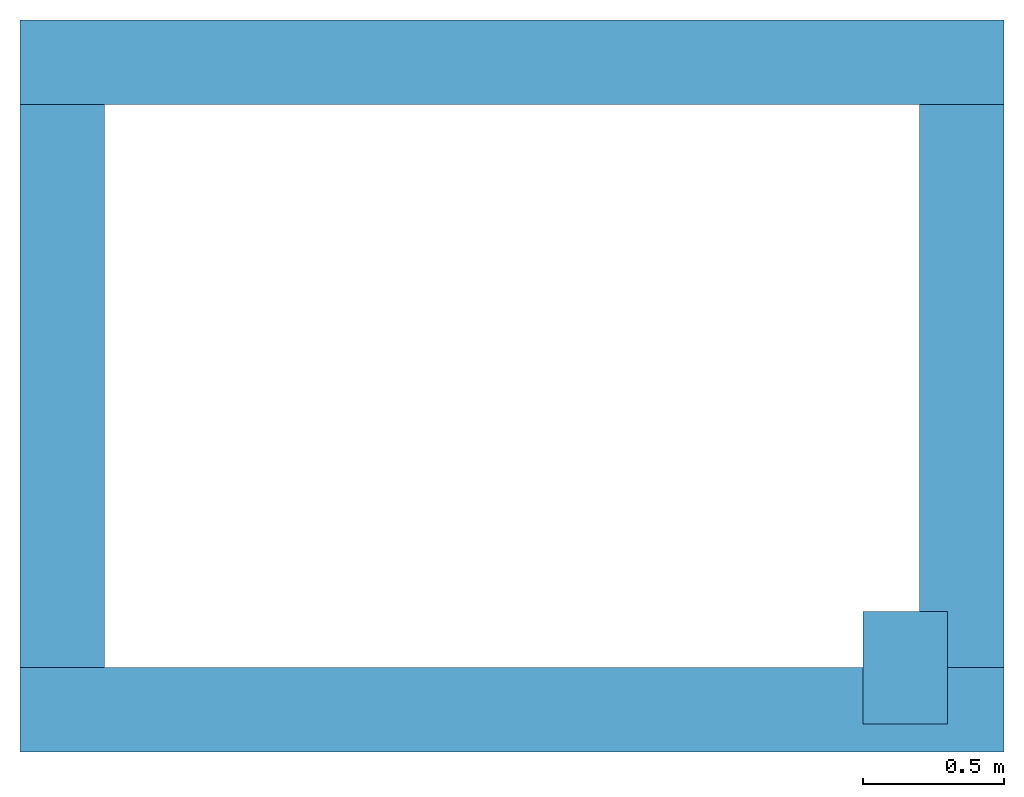
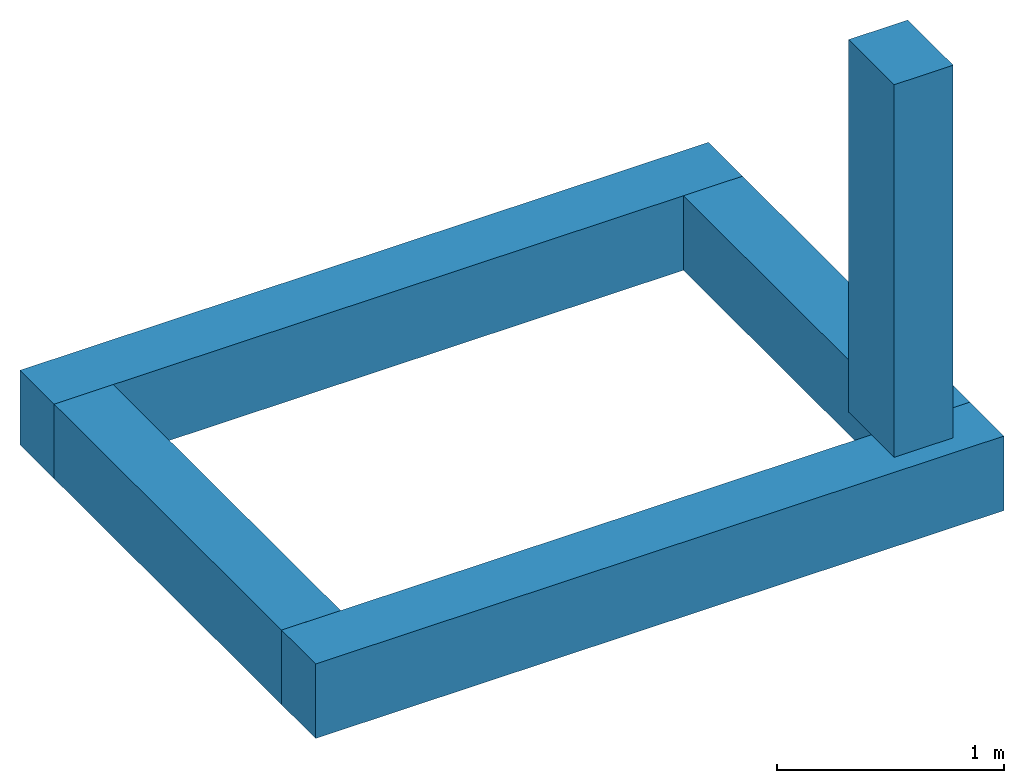
# One storey: 5 beams.
"""IFC4 building model written with IfcOpenShell, lengths in metres."""

from ifc_helpers import new_model, entity, si_unit, converted_unit, frame, frame_2d, origin_with_axes, place, context, subcontext, project, spatial, rectangle, extrude, material, material_profile, profile_set, profile_usage, type_object, element, save


model = new_model("IFC4")

# Units and contexts
model_context = context("Model", 3, precision=1e-05, world=origin_with_axes())
plan_context = context("Plan", 2, precision=1e-05, world=frame_2d((0.0, 0.0, 0.0), x_axis=(1.0, 0.0, 0.0)))
body_context = subcontext(model_context, "Body", "Model", "MODEL_VIEW")
ifc_project = project(units=[si_unit("LENGTHUNIT", "METRE"), converted_unit("PLANEANGLEUNIT", "degree", entity("IfcReal", 0.0174532925199433), si_unit("PLANEANGLEUNIT", "RADIAN"), dimensions=[0, 0, 0, 0, 0, 0, 0]), si_unit("AREAUNIT", "SQUARE_METRE"), si_unit("VOLUMEUNIT", "CUBIC_METRE")], contexts=[model_context, plan_context])

# Site, building, storey
site_placement = place(None, origin_with_axes())
site = spatial("IfcSite", under=ifc_project, at=site_placement)
building_placement = place(site_placement, origin_with_axes())
building = spatial("IfcBuilding", under=site, at=building_placement, Name="Building")
storey_placement = place(building_placement, origin_with_axes())
storey = spatial("IfcBuildingStorey", under=building, at=storey_placement, Name="Storey")

# Beams
ifc_material = material(Name="vuren")
ifc_material_profile = material_profile(ifc_material, rectangle(XDim=0.300000011920929, YDim=0.400000005960464))
ifc_profile_set = profile_set([ifc_material_profile])
ifc_profile_usage_1 = profile_usage(ifc_profile_set)
beam_type = type_object("IfcBeamType", Name="balk", PredefinedType="BEAM", material=ifc_profile_set)
beam_1_placement = place(storey_placement, frame((0.349999964237213, 0.100000113248825, -0.200000032782555), z_axis=(1.0, 4.37113882867379e-08, -4.37113882867379e-08), x_axis=(-4.37113882867379e-08, 1.0, 0.0)))
element("IfcBeam", 1, at=beam_1_placement, inside=storey, type_object=beam_type, material=ifc_profile_usage_1, Name="Beam", context=body_context, shape_type="SweptSolid", body=[
    extrude(rectangle(XDim=0.300000011920929, YDim=0.400000005960464), None, (0.0, 0.0, 1.0), 3.49483203887939),
])
ifc_profile_usage_2 = profile_usage(ifc_profile_set)
beam_2_placement = place(storey_placement, frame((0.499999970197678, 0.250000149011612, -0.200000032782555), z_axis=(-3.89414367418794e-07, 1.0, -1.62920684942947e-07), x_axis=(-1.0, -3.89414367418794e-07, -7.36919087627715e-15)))
element("IfcBeam", 2, at=beam_2_placement, inside=storey, type_object=beam_type, material=ifc_profile_usage_2, Name="Beam", context=body_context, shape_type="SweptSolid", body=[
    extrude(rectangle(XDim=0.300000011920929, YDim=0.400000005960464), None, (0.0, 0.0, 1.0), 2.0),
])
ifc_profile_usage_3 = profile_usage(ifc_profile_set)
beam_3_placement = place(storey_placement, frame((3.69483208656311, 0.250000506639481, -0.200000181794167), z_axis=(-3.89414367418794e-07, 1.0, -1.62920684942947e-07), x_axis=(-1.0, -3.89414367418794e-07, -7.36919087627715e-15)))
element("IfcBeam", 3, at=beam_3_placement, inside=storey, type_object=beam_type, material=ifc_profile_usage_3, Name="Beam", context=body_context, shape_type="SweptSolid", body=[
    extrude(rectangle(XDim=0.300000011920929, YDim=0.400000005960464), None, (0.0, 0.0, 1.0), 2.0),
])
ifc_profile_usage_4 = profile_usage(ifc_profile_set)
beam_4_placement = place(storey_placement, frame((3.49483203887939, 0.250000089406967, 0.0), z_axis=(0.0, 0.0, 1.0), x_axis=(1.0, 0.0, 0.0)))
element("IfcBeam", 4, at=beam_4_placement, inside=storey, type_object=beam_type, material=ifc_profile_usage_4, Name="Beam", context=body_context, shape_type="SweptSolid", body=[
    extrude(rectangle(XDim=0.300000011920929, YDim=0.400000005960464), None, (0.0, 0.0, 1.0), 2.0),
])
ifc_profile_usage_5 = profile_usage(ifc_profile_set)
beam_5_placement = place(storey_placement, frame((0.349999189376831, 2.40000033378601, -0.200000360608101), z_axis=(1.0, 4.37113882867379e-08, -4.37113882867379e-08), x_axis=(-4.37113882867379e-08, 1.0, 0.0)))
element("IfcBeam", 5, at=beam_5_placement, inside=storey, type_object=beam_type, material=ifc_profile_usage_5, Name="Beam", context=body_context, shape_type="SweptSolid", body=[
    extrude(rectangle(XDim=0.300000011920929, YDim=0.400000005960464), None, (0.0, 0.0, 1.0), 3.49483203887939),
])

save(model, "model.ifc")
